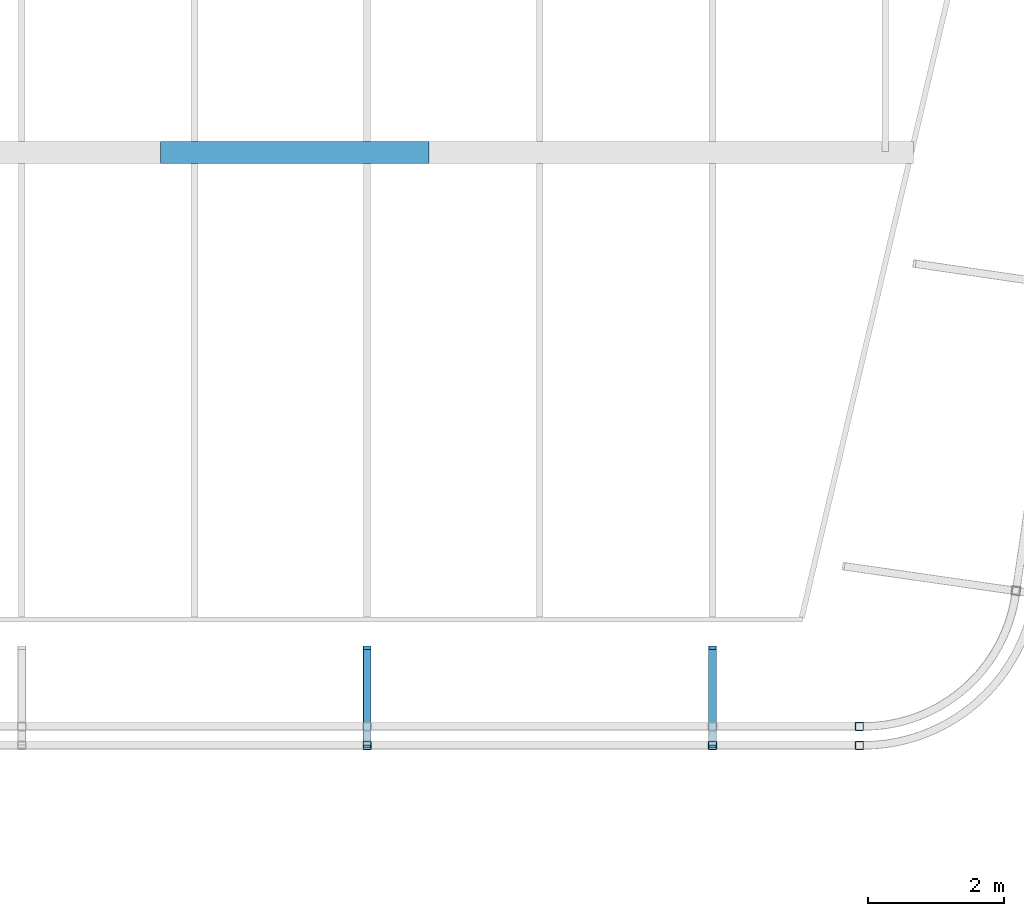
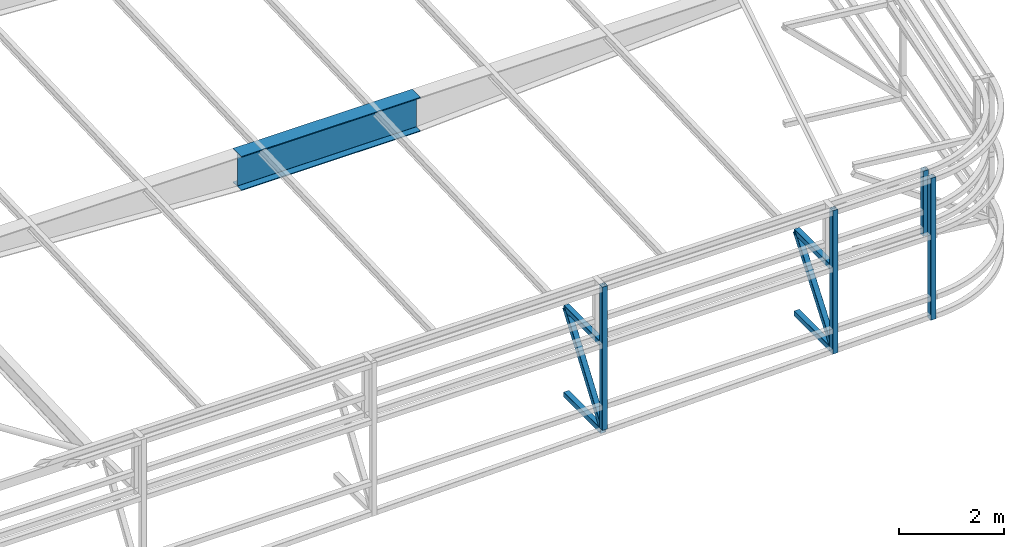
# One storey, part 117 of 215: 9 beams, 2 members, 11 elements without a shape of their own.
"""IFC2X3 building model written with IfcOpenShell, lengths in millimetres."""

import ifcopenshell
import ifcopenshell.guid

model = None  # the IFC model being written
_history = None  # IfcOwnerHistory: only IFC2X3 demands one
_inside = {}  # id of a spatial element -> (the spatial element, [elements in it])
_under = {}  # id of a project, library or spatial element -> (it, [spatial elements below it])
_declared = {}  # id of a project -> (the project, [libraries it declares])
_typed = {}  # id of a type object -> (the type object, [elements of that type])
_made_of = {}  # id of a material, layer set ... -> (it, [elements and type objects made of it])


def new_model(schema):
    """Start an empty IFC model of exactly this schema.

    Asked for "IFC4X3", IfcOpenShell would pick the latest addendum, in which some entities
    have other attributes; the version numbers below select the first issue.
    IFC2X3 requires an IfcOwnerHistory on every rooted entity: one is made here for all.
    """
    global model, _history
    if schema == "IFC4X3":
        model = ifcopenshell.file(schema_version=(4, 3, 0, 0))
    else:
        model = ifcopenshell.file(schema=schema)
    _inside.clear()
    _under.clear()
    _declared.clear()
    _typed.clear()
    _made_of.clear()
    _history = None
    if model.schema == "IFC2X3":
        org = make("IfcOrganization", Name="unknown")
        user = make(
            "IfcPersonAndOrganization",
            ThePerson=make("IfcPerson", FamilyName="unknown"),
            TheOrganization=org,
        )
        app = make(
            "IfcApplication",
            ApplicationDeveloper=org,
            Version="unknown",
            ApplicationFullName="unknown",
            ApplicationIdentifier="unknown",
        )
        _history = make(
            "IfcOwnerHistory",
            OwningUser=user,
            OwningApplication=app,
            ChangeAction="ADDED",
            CreationDate=0,
        )
    return model


def make(cls, **values):
    """One entity of the class cls with the attributes given. An attribute that is None is left unset."""
    return model.create_entity(
        cls, **{name: value for name, value in values.items() if value is not None}
    )


def rooted(cls, **values):
    """An entity with a GlobalId (a new one), such as an element, a storey or a relation."""
    return make(cls, GlobalId=ifcopenshell.guid.new(), OwnerHistory=_history, **values)


def si_unit(unit_type, name, prefix=None):
    """IfcSIUnit, for example si_unit("LENGTHUNIT", "METRE", prefix="MILLI")."""
    return make("IfcSIUnit", UnitType=unit_type, Prefix=prefix, Name=name)


def assignment(units):
    """IfcUnitAssignment: the units of a project."""
    return None if units is None else make("IfcUnitAssignment", Units=units)


def point(xyz):
    """IfcCartesianPoint."""
    return None if xyz is None else make("IfcCartesianPoint", Coordinates=xyz)


def direction(xyz):
    """IfcDirection."""
    return None if xyz is None else make("IfcDirection", DirectionRatios=xyz)


def frame(location, z_axis=None, x_axis=None):
    """IfcAxis2Placement3D, a coordinate frame: its origin and axes. An axis left out is left unset."""
    return make(
        "IfcAxis2Placement3D",
        Location=point(location),
        Axis=direction(z_axis),
        RefDirection=direction(x_axis),
    )


def frame_2d(location, x_axis=None):
    """IfcAxis2Placement2D, a coordinate frame in the plane: its origin and x axis."""
    return make(
        "IfcAxis2Placement2D", Location=point(location), RefDirection=direction(x_axis)
    )


def origin_with_axes():
    """The frame at (0, 0, 0) with the z axis (0, 0, 1) and the x axis (1, 0, 0) written out."""
    return frame((0.0, 0.0, 0.0), z_axis=(0.0, 0.0, 1.0), x_axis=(1.0, 0.0, 0.0))


def origin_2d_with_axis():
    """The frame at (0, 0) in the plane with the x axis (1, 0) written out."""
    return frame_2d((0.0, 0.0), x_axis=(1.0, 0.0))


def place(relative_to, where):
    """IfcLocalPlacement: puts the frame where relative to a parent placement (None: the world)."""
    return make(
        "IfcLocalPlacement", PlacementRelTo=relative_to, RelativePlacement=where
    )


def context(
    kind, dimensions, precision=None, world=None, true_north=None, identifier=None
):
    """IfcGeometricRepresentationContext, for example the 3D "Model" context."""
    return make(
        "IfcGeometricRepresentationContext",
        ContextIdentifier=identifier,
        ContextType=kind,
        CoordinateSpaceDimension=dimensions,
        Precision=precision,
        WorldCoordinateSystem=world,
        TrueNorth=true_north,
    )


def subcontext(parent, identifier, kind, view, scale=None):
    """IfcGeometricRepresentationSubContext, for example "Body" below "Model"."""
    return make(
        "IfcGeometricRepresentationSubContext",
        ContextIdentifier=identifier,
        ContextType=kind,
        ParentContext=parent,
        TargetScale=scale,
        TargetView=view,
    )


def project(units=None, contexts=None):
    """IfcProject with its units and contexts."""
    return rooted(
        "IfcProject",
        Name="project",
        RepresentationContexts=contexts,
        UnitsInContext=assignment(units),
    )


def spatial(cls, under=None, at=None, **own):
    """A site, building, storey or space (cls), placed at a placement, below another one or the project."""
    s = rooted(cls, ObjectPlacement=at, **own)
    if under is not None:
        _under.setdefault(under.id(), (under, []))[1].append(s)
    return s


def profile(cls, at=None, kind="AREA", **sizes):
    """A parametric profile (cls). Its sizes go by their IFC names, for example OverallWidth=200.0."""
    return make(cls, ProfileType=kind, Position=at, **sizes)


def hollow_rectangle(**sizes):
    """IfcRectangleHollowProfileDef."""
    return profile("IfcRectangleHollowProfileDef", **sizes)


def i_section(**sizes):
    """IfcIShapeProfileDef."""
    return profile("IfcIShapeProfileDef", **sizes)


def extrude(swept, where, along, depth):
    """IfcExtrudedAreaSolid: the profile swept, set in the frame where, extruded along a direction by depth."""
    return make(
        "IfcExtrudedAreaSolid",
        SweptArea=swept,
        Position=where,
        ExtrudedDirection=direction(along),
        Depth=depth,
    )


def shape(context_of_items, identifier, shape_type, items):
    """IfcShapeRepresentation: the items that make up one representation, for example the "Body"."""
    return make(
        "IfcShapeRepresentation",
        ContextOfItems=context_of_items,
        RepresentationIdentifier=identifier,
        RepresentationType=shape_type,
        Items=items,
    )


def material(Name=None, Category=None):
    """IfcMaterial."""
    return make("IfcMaterial", Name=Name, Category=Category)


def made_of(thing, what):
    """Note that an element or type object is made of a material, layer set ...; save() writes the relation."""
    if what is not None:
        _made_of.setdefault(what.id(), (what, []))[1].append(thing)
    return thing


def type_object(cls, material=None, **own):
    """A type object (cls), such as IfcWallType, which elements share."""
    return made_of(rooted(cls, **own), material)


def element(
    cls,
    number,
    at=None,
    inside=None,
    cuts=None,
    type_object=None,
    material=None,
    context=None,
    identifier="Body",
    shape_type=None,
    held_by="IfcProductDefinitionShape",
    body=None,
    shapes=None,
    **own,
):
    """One element of the class cls, such as IfcWall. Its Tag is "e" and its number.

    at: its placement. inside: the storey or other place that contains it. cuts: it is an
    opening in that element (IfcRelVoidsElement). A single representation is given by context,
    identifier, shape_type and body (its items); several are given by shapes. held_by: the class
    of the entity that holds the representations. save() writes the other relations.
    """
    e = rooted(cls, Tag="e%d" % number, ObjectPlacement=at, **own)
    if body is not None:
        shapes = [shape(context, identifier, shape_type, body)]
    if shapes is not None:
        e.Representation = make(held_by, Representations=shapes)
    if inside is not None:
        _inside.setdefault(inside.id(), (inside, []))[1].append(e)
    if cuts is not None:
        rooted(
            "IfcRelVoidsElement", RelatingBuildingElement=cuts, RelatedOpeningElement=e
        )
    if type_object is not None:
        _typed.setdefault(type_object.id(), (type_object, []))[1].append(e)
    return made_of(e, material)


def aggregate(whole, parts):
    """IfcRelAggregates: a whole, such as a stair, and the parts it consists of."""
    return rooted("IfcRelAggregates", RelatingObject=whole, RelatedObjects=parts)


def save(model, path):
    """Write the relations noted so far, then the file.

    IfcRelAggregates (storeys below a building ...), IfcRelContainedInSpatialStructure (elements
    in a storey), IfcRelDefinesByType, IfcRelAssociatesMaterial and IfcRelDeclares: one each for
    every whole, place, type object, material and project.
    """
    for whole, parts in _under.values():
        aggregate(whole, parts)
    for where, things in _inside.values():
        rooted(
            "IfcRelContainedInSpatialStructure",
            RelatedElements=things,
            RelatingStructure=where,
        )
    for kind, things in _typed.values():
        rooted("IfcRelDefinesByType", RelatedObjects=things, RelatingType=kind)
    for what, things in _made_of.values():
        rooted("IfcRelAssociatesMaterial", RelatedObjects=things, RelatingMaterial=what)
    for by, libraries in _declared.values():
        rooted("IfcRelDeclares", RelatingContext=by, RelatedDefinitions=libraries)
    model.write(path)


model = new_model("IFC2X3")

# Units and contexts
model_context = context("Model", 3, precision=1e-05, world=origin_with_axes())
body_context = subcontext(model_context, "Body", "Model", "MODEL_VIEW")
ifc_project = project(units=[si_unit("LENGTHUNIT", "METRE", prefix="MILLI"), si_unit("AREAUNIT", "SQUARE_METRE"), si_unit("VOLUMEUNIT", "CUBIC_METRE"), si_unit("MASSUNIT", "GRAM", prefix="KILO"), si_unit("TIMEUNIT", "SECOND"), si_unit("PLANEANGLEUNIT", "RADIAN"), si_unit("SOLIDANGLEUNIT", "STERADIAN"), si_unit("THERMODYNAMICTEMPERATUREUNIT", "DEGREE_CELSIUS"), si_unit("LUMINOUSINTENSITYUNIT", "LUMEN")], contexts=[model_context])

# Site, building, storey
site_placement = place(None, origin_with_axes())
site = spatial("IfcSite", under=ifc_project, at=site_placement, CompositionType="ELEMENT")
building_placement = place(site_placement, origin_with_axes())
building = spatial("IfcBuilding", under=site, at=building_placement, Name="Undefined", CompositionType="ELEMENT")
storey_placement = place(building_placement, origin_with_axes())
storey = spatial("IfcBuildingStorey", under=building, at=storey_placement, Name="Undefined", CompositionType="ELEMENT", Elevation=0.0)

# Assembly, beam
assembly_1_placement = place(storey_placement, origin_with_axes())
assembly_1 = element("IfcElementAssembly", 1, at=assembly_1_placement, inside=storey, Name="Steel Assembly", AssemblyPlace="NOTDEFINED", PredefinedType="RIGID_FRAME")
ifc_material_1 = material(Name="STEEL/S275JR")
beam_type_1 = type_object("IfcBeamType", PredefinedType="NOTDEFINED")
beam_1_placement = place(assembly_1_placement, frame((146924.872067617, 33420.024412574, 4339.19097189379), z_axis=(-6.93889390390723e-18, -1.0, -3.46944695195361e-18), x_axis=(0.0, 0.0, -1.0)))
beam_1 = element("IfcBeam", 2, at=beam_1_placement, type_object=beam_type_1, material=ifc_material_1, Name="LISSE", context=body_context, shape_type="SweptSolid", body=[
    extrude(hollow_rectangle(XDim=120.0, YDim=120.0, WallThickness=4.0, InnerFilletRadius=4.0, OuterFilletRadius=8.0, at=origin_2d_with_axis()), frame((1522.3234559442, 0.0, 0.0), z_axis=(-1.0, 0.0, 0.0), x_axis=(-6.93889390390723e-18, -1.0, -3.46944695195361e-18)), (0.0, 0.0, 1.0), 1522.3),
])
aggregate(assembly_1, [beam_1])

assembly_2_placement = place(storey_placement, origin_with_axes())
assembly_2 = element("IfcElementAssembly", 3, at=assembly_2_placement, inside=storey, Name="Steel Assembly", AssemblyPlace="NOTDEFINED", PredefinedType="RIGID_FRAME")
beam_2_placement = place(assembly_2_placement, frame((144765.010709088, 34554.9435255155, 2963.99602185051), z_axis=(0.0, 0.0, -1.0), x_axis=(-4.41999996209638e-07, -0.999999999999642, 7.22000000069896e-07)))
beam_2 = element("IfcBeam", 4, at=beam_2_placement, type_object=beam_type_1, material=ifc_material_1, Name="LISSE", context=body_context, shape_type="SweptSolid", body=[
    extrude(hollow_rectangle(XDim=120.0, YDim=120.0, WallThickness=4.0, InnerFilletRadius=4.0, OuterFilletRadius=8.0, at=origin_2d_with_axis()), frame((1404.89231313232, 5.39143026605448e-20, -1.48748759570922e-19), z_axis=(-1.0, 0.0, 0.0), x_axis=(-6.93889390390723e-18, -1.0, -3.46944695195361e-18)), (0.0, 0.0, 1.0), 1404.9),
])
aggregate(assembly_2, [beam_2])

assembly_3_placement = place(storey_placement, origin_with_axes())
assembly_3 = element("IfcElementAssembly", 5, at=assembly_3_placement, inside=storey, Name="Steel Assembly", AssemblyPlace="NOTDEFINED", PredefinedType="RIGID_FRAME")
beam_3_placement = place(assembly_3_placement, frame((139685.011201121, 34554.9338049677, 2963.99602185051), z_axis=(0.0, 0.0, -1.0), x_axis=(-4.41999996209638e-07, -0.999999999999642, 7.22000000069896e-07)))
beam_3 = element("IfcBeam", 6, at=beam_3_placement, type_object=beam_type_1, material=ifc_material_1, Name="LISSE", context=body_context, shape_type="SweptSolid", body=[
    extrude(hollow_rectangle(XDim=120.0, YDim=120.0, WallThickness=4.0, InnerFilletRadius=4.0, OuterFilletRadius=8.0, at=origin_2d_with_axis()), frame((1404.89231313232, 5.39143026605448e-20, -1.48748759570922e-19), z_axis=(-1.0, 0.0, 0.0), x_axis=(-6.93889390390723e-18, -1.0, -3.46944695195361e-18)), (0.0, 0.0, 1.0), 1404.9),
])
aggregate(assembly_3, [beam_3])

assembly_4_placement = place(storey_placement, origin_with_axes())
assembly_4 = element("IfcElementAssembly", 7, at=assembly_4_placement, inside=storey, Name="Steel Assembly", AssemblyPlace="NOTDEFINED", PredefinedType="RIGID_FRAME")
beam_4_placement = place(assembly_4_placement, frame((139685.010918709, 33139.9744401047, 4339.1909718032), z_axis=(1.91399999311775e-06, -0.999999999998168, 0.0), x_axis=(0.0, 0.0, -1.0)))
beam_4 = element("IfcBeam", 8, at=beam_4_placement, type_object=beam_type_1, material=ifc_material_1, Name="LISSE", context=body_context, shape_type="SweptSolid", body=[
    extrude(hollow_rectangle(XDim=120.0, YDim=120.0, WallThickness=4.0, InnerFilletRadius=4.0, OuterFilletRadius=8.0, at=origin_2d_with_axis()), frame((3343.10625629259, 0.0, 0.0), z_axis=(-1.0, 0.0, 0.0), x_axis=(-6.93889390390723e-18, -1.0, -3.46944695195361e-18)), (0.0, 0.0, 1.0), 3343.1),
])
aggregate(assembly_4, [beam_4])

assembly_5_placement = place(storey_placement, origin_with_axes())
assembly_5 = element("IfcElementAssembly", 9, at=assembly_5_placement, inside=storey, Name="Steel Assembly", AssemblyPlace="NOTDEFINED", PredefinedType="RIGID_FRAME")
beam_5_placement = place(assembly_5_placement, frame((139685.009793245, 34554.9372104841, 940.947033135467), z_axis=(0.0, 0.0, 1.0), x_axis=(-6.93889390390723e-18, -1.0, -3.46944695195361e-18)))
beam_5 = element("IfcBeam", 10, at=beam_5_placement, type_object=beam_type_1, material=ifc_material_1, Name="LISSE", context=body_context, shape_type="SweptSolid", body=[
    extrude(hollow_rectangle(XDim=120.0, YDim=120.0, WallThickness=4.0, InnerFilletRadius=4.0, OuterFilletRadius=8.0, at=origin_2d_with_axis()), frame((1404.9181154153, 1.48751491493898e-19, -2.84217094304217e-14), z_axis=(-1.0, 0.0, 0.0), x_axis=(-6.93889390390723e-18, -1.0, -3.46944695195361e-18)), (0.0, 0.0, 1.0), 1404.9),
])
aggregate(assembly_5, [beam_5])

assembly_6_placement = place(storey_placement, origin_with_axes())
assembly_6 = element("IfcElementAssembly", 11, at=assembly_6_placement, inside=storey, Name="Steel Assembly", AssemblyPlace="NOTDEFINED", PredefinedType="RIGID_FRAME")
beam_6_placement = place(assembly_6_placement, frame((146924.872603883, 33139.989565561, 4339.19097189418), z_axis=(-6.93889390390723e-18, -1.0, -3.46944695195361e-18), x_axis=(0.0, 0.0, -1.0)))
beam_6 = element("IfcBeam", 12, at=beam_6_placement, type_object=beam_type_1, material=ifc_material_1, Name="LISSE", context=body_context, shape_type="SweptSolid", body=[
    extrude(hollow_rectangle(XDim=120.0, YDim=120.0, WallThickness=4.0, InnerFilletRadius=4.0, OuterFilletRadius=8.0, at=origin_2d_with_axis()), frame((3309.18882166953, 0.0, 0.0), z_axis=(-1.0, 0.0, 0.0), x_axis=(-6.93889390390723e-18, -1.0, -3.46944695195361e-18)), (0.0, 0.0, 1.0), 3309.2),
])
aggregate(assembly_6, [beam_6])

assembly_7_placement = place(storey_placement, origin_with_axes())
assembly_7 = element("IfcElementAssembly", 13, at=assembly_7_placement, inside=storey, Name="Steel Assembly", AssemblyPlace="NOTDEFINED", PredefinedType="RIGID_FRAME")
beam_7_placement = place(assembly_7_placement, frame((144765.010109023, 33139.9817000486, 4339.19097185521), z_axis=(1.91399999311775e-06, -0.999999999998168, 0.0), x_axis=(0.0, 0.0, -1.0)))
beam_7 = element("IfcBeam", 14, at=beam_7_placement, type_object=beam_type_1, material=ifc_material_1, Name="LISSE", context=body_context, shape_type="SweptSolid", body=[
    extrude(hollow_rectangle(XDim=120.0, YDim=120.0, WallThickness=4.0, InnerFilletRadius=4.0, OuterFilletRadius=8.0, at=origin_2d_with_axis()), frame((3343.10625629259, 0.0, 0.0), z_axis=(-1.0, 0.0, 0.0), x_axis=(-6.93889390390723e-18, -1.0, -3.46944695195361e-18)), (0.0, 0.0, 1.0), 3343.1),
])
aggregate(assembly_7, [beam_7])

assembly_8_placement = place(storey_placement, origin_with_axes())
assembly_8 = element("IfcElementAssembly", 15, at=assembly_8_placement, inside=storey, Name="Steel Assembly", AssemblyPlace="NOTDEFINED", PredefinedType="RIGID_FRAME")
beam_8_placement = place(assembly_8_placement, frame((144765.011195138, 34554.9372105013, 1054.74712519048), z_axis=(0.0, 0.0, 1.0), x_axis=(-6.93889390390723e-18, -1.0, -3.46944695195361e-18)))
beam_8 = element("IfcBeam", 16, at=beam_8_placement, type_object=beam_type_1, material=ifc_material_1, Name="LISSE", context=body_context, shape_type="SweptSolid", body=[
    extrude(hollow_rectangle(XDim=120.0, YDim=120.0, WallThickness=4.0, InnerFilletRadius=4.0, OuterFilletRadius=8.0, at=origin_2d_with_axis()), frame((1404.9181154153, 1.48751491493898e-19, -2.84217094304217e-14), z_axis=(-1.0, 0.0, 0.0), x_axis=(-6.93889390390723e-18, -1.0, -3.46944695195361e-18)), (0.0, 0.0, 1.0), 1404.9),
])
aggregate(assembly_8, [beam_8])

assembly_9_placement = place(storey_placement, origin_with_axes())
assembly_9 = element("IfcElementAssembly", 17, at=assembly_9_placement, inside=storey, Name="Steel Assembly", AssemblyPlace="NOTDEFINED", PredefinedType="RIGID_FRAME")
ifc_material_2 = material(Name="STEEL/S355JR")
beam_type_2 = type_object("IfcBeamType", PredefinedType="NOTDEFINED")
beam_9_placement = place(assembly_9_placement, frame((136647.173930158, 41861.7757501745, 2798.87694895525), z_axis=(0.0, 0.0, -1.0), x_axis=(1.0, 0.0, 0.0)))
beam_9 = element("IfcBeam", 18, at=beam_9_placement, type_object=beam_type_2, material=ifc_material_2, Name="POUTRE", context=body_context, shape_type="SweptSolid", body=[
    extrude(i_section(OverallWidth=320.0, OverallDepth=800.0, WebThickness=6.0, FlangeThickness=20.0, FilletRadius=4.2, at=origin_2d_with_axis()), frame((3950.33267238559, 0.0, 0.0), z_axis=(-1.0, 0.0, 0.0), x_axis=(-6.93889390390723e-18, -1.0, -3.46944695195361e-18)), (0.0, 0.0, 1.0), 3950.3),
])
aggregate(assembly_9, [beam_9])

# Assembly, member
assembly_10_placement = place(storey_placement, origin_with_axes())
assembly_10 = element("IfcElementAssembly", 19, at=assembly_10_placement, inside=storey, Name="Steel Assembly", AssemblyPlace="NOTDEFINED", PredefinedType="RIGID_FRAME")
member_type = type_object("IfcMemberType", PredefinedType="NOTDEFINED")
member_1_placement = place(assembly_10_placement, frame((144765.010146782, 33150.0190950727, 1114.74712519058), z_axis=(-0.000492795999985103, -0.796266748966378, 0.604945469974458), x_axis=(1.94299999862319e-06, 0.604945542988468, 0.79626684598482)))
member_1 = element("IfcMember", 20, at=member_1_placement, type_object=member_type, material=ifc_material_1, Name="LISSE", context=body_context, shape_type="SweptSolid", body=[
    extrude(hollow_rectangle(XDim=120.0, YDim=120.0, WallThickness=4.0, InnerFilletRadius=4.0, OuterFilletRadius=8.0, at=origin_2d_with_axis()), frame((2322.39845047657, 2.91037675079976e-11, -3.76689781869536e-12), z_axis=(-1.0, 0.0, 0.0), x_axis=(-6.93889390390723e-18, -1.0, -3.46944695195361e-18)), (0.0, 0.0, 1.0), 2322.4),
])
aggregate(assembly_10, [member_1])

assembly_11_placement = place(storey_placement, origin_with_axes())
assembly_11 = element("IfcElementAssembly", 21, at=assembly_11_placement, inside=storey, Name="Steel Assembly", AssemblyPlace="NOTDEFINED", PredefinedType="RIGID_FRAME")
member_2_placement = place(assembly_11_placement, frame((139685.014377527, 33150.0192568697, 1000.94702563547), z_axis=(-0.00186075700068241, -0.813195518303631, 0.581987617217302), x_axis=(-1.31700000516593e-06, 0.581988626770541, 0.813196924679382)))
member_2 = element("IfcMember", 22, at=member_2_placement, type_object=member_type, material=ifc_material_1, Name="LISSE", context=body_context, shape_type="SweptSolid", body=[
    extrude(hollow_rectangle(XDim=120.0, YDim=120.0, WallThickness=4.0, InnerFilletRadius=4.0, OuterFilletRadius=8.0, at=origin_2d_with_axis()), frame((2413.98969503312, -2.61725287171253e-16, 2.68006694063363e-13), z_axis=(-1.0, 0.0, 0.0), x_axis=(-6.93889390390723e-18, -1.0, -3.46944695195361e-18)), (0.0, 0.0, 1.0), 2414.0),
])
aggregate(assembly_11, [member_2])

save(model, "model.ifc")
